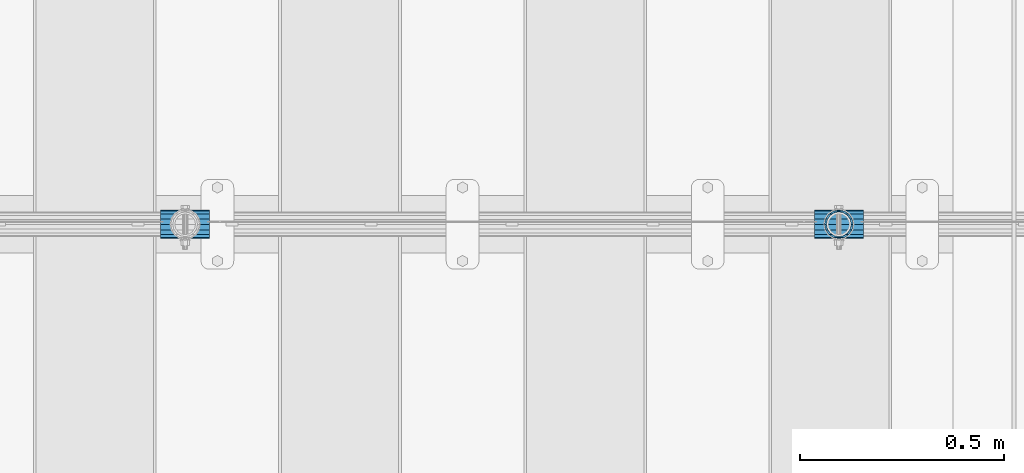
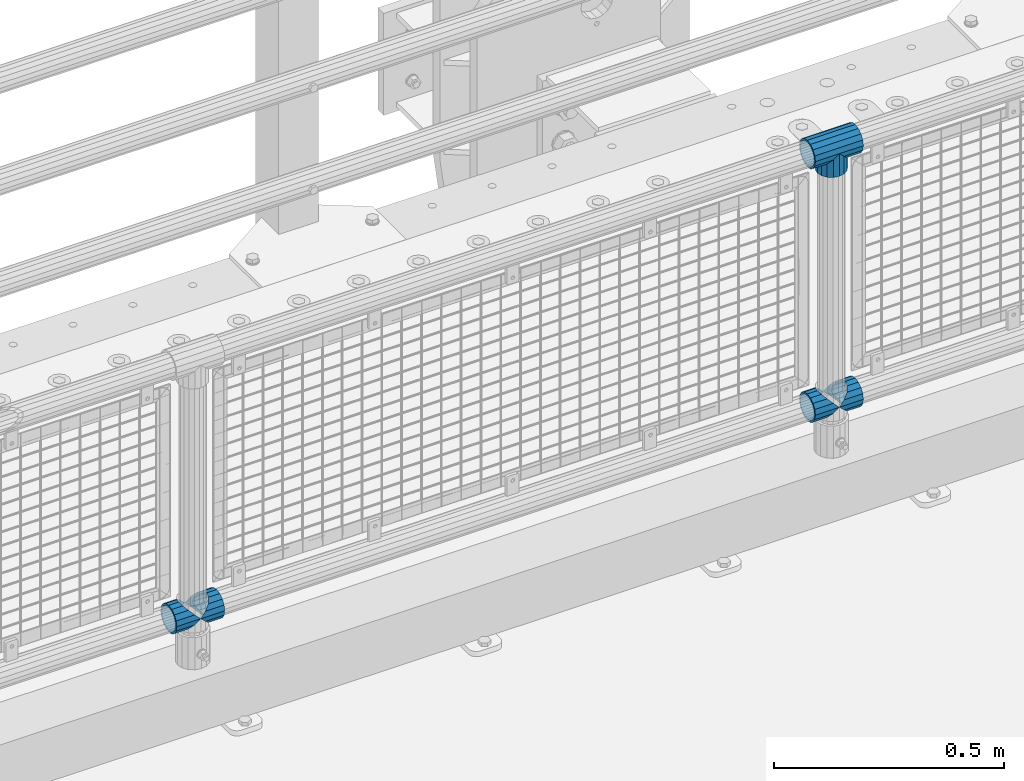
# One storey, part 156 of 257: 6 beams.
"""IFC2X3 building model written with IfcOpenShell, lengths in millimetres."""

from ifc_helpers import new_model, si_unit, frame, origin_with_axes, place, context, subcontext, project, spatial, faceted_brep, material, type_object, element, save


model = new_model("IFC2X3")

# Units and contexts
model_context = context("Model", 3, precision=1e-05, world=origin_with_axes())
body_context = subcontext(model_context, "Body", "Model", "MODEL_VIEW")
ifc_project = project(units=[si_unit("LENGTHUNIT", "METRE", prefix="MILLI"), si_unit("AREAUNIT", "SQUARE_METRE"), si_unit("VOLUMEUNIT", "CUBIC_METRE"), si_unit("MASSUNIT", "GRAM", prefix="KILO"), si_unit("TIMEUNIT", "SECOND"), si_unit("PLANEANGLEUNIT", "RADIAN"), si_unit("SOLIDANGLEUNIT", "STERADIAN"), si_unit("THERMODYNAMICTEMPERATUREUNIT", "DEGREE_CELSIUS"), si_unit("LUMINOUSINTENSITYUNIT", "LUMEN")], contexts=[model_context])

# Site, building, storey
site_placement = place(None, origin_with_axes())
site = spatial("IfcSite", under=ifc_project, at=site_placement, CompositionType="ELEMENT")
building_placement = place(site_placement, origin_with_axes())
building = spatial("IfcBuilding", under=site, at=building_placement, Name="Standard", CompositionType="ELEMENT")
storey_placement = place(building_placement, origin_with_axes())
storey = spatial("IfcBuildingStorey", under=building, at=storey_placement, Name="Undefined", CompositionType="ELEMENT", Elevation=0.0)

# Beams
ifc_material = material(Name="Misc_Undefined")
beam_type = type_object("IfcBeamType", PredefinedType="NOTDEFINED")
beam_1_placement = place(storey_placement, frame((54271.0, 10664.5, 969.849999999999), z_axis=(0.0, 1.0, 0.0), x_axis=(0.0, 0.0, -1.0)))
element("IfcBeam", 1, at=beam_1_placement, inside=storey, type_object=beam_type, material=ifc_material, context=body_context, shape_type="Brep", body=[
    faceted_brep([(0.0, 0.0, 35.1499999999996), (13.4513226476338, 13.4513226476329, 32.4743655677721), (13.4513226476338, -13.4513226476329, 32.4743655677721), (32.4743655677739, -32.4743655677717, -13.4513226476338), (32.4743655677739, -26.8123795176755, -13.4513226476338), (27.1226768591005, -21.4606908090117, -21.4606908090118), (24.8548033587067, -16.3810424080045, -24.8548033587067), (24.8548033587067, -24.8548033587072, -24.8548033587067), (13.4513226476338, -13.4513226476329, -32.4743655677721), (13.4513226476338, 13.4513226476329, -32.4743655677721), (0.0, 0.0, -35.1499999999996), (20.0882031229849, -11.6144421722805, -28.0397438117179), (16.6306603983685, 0.0, -30.3500000000004), (20.0882031229849, 11.6144421722805, -28.0397438117179), (24.8548033587067, 16.3810424080013, -24.8548033587067), (24.8548033587067, 24.8548033587072, -24.8548033587067), (32.4743655677739, 26.8123795176754, -13.4513226476338), (32.4743655677739, 32.4743655677717, -13.4513226476338), (27.1226768591005, 21.4606908090117, -21.4606908090118), (35.1500000000015, 30.35, 0.0), (35.1500000000015, 35.15, 0.0), (32.8397438117172, 28.0397438117175, -11.6144421722802), (32.8397438117172, 28.0397438117175, 11.6144421722802), (32.4743655677739, 26.8123795176755, 13.4513226476338), (32.4743655677739, 32.4743655677717, 13.4513226476338), (27.122676859115, 21.4606908090117, 21.4606908090118), (24.8548033587067, 16.3810424080013, 24.8548033587067), (24.8548033587067, 24.8548033587072, 24.8548033587067), (20.0882031229849, 11.6144421722805, 28.0397438117179), (16.6306603983758, 0.0, 30.3500000000004), (20.0882031229849, -11.6144421722805, 28.0397438117179), (24.8548033587067, -16.3810424080013, 24.8548033587067), (24.8548033587067, -24.8548033587072, 24.8548033587067), (27.122676859115, -21.4606908090117, 21.4606908090118), (32.4743655677739, -26.8123795176754, 13.4513226476338), (32.4743655677739, -32.4743655677717, 13.4513226476338), (32.8397438117172, -28.0397438117175, 11.6144421722802), (35.1500000000015, -30.35, 0.0), (35.1500000000015, -35.1499999999996, 0.0), (32.8397438117172, -28.0397438117175, -11.6144421722802), (60.1500000000015, -24.8548033587072, -24.8548033587067), (60.1500000000015, -32.4743655677717, -13.4513226476338), (60.1500000000015, -13.4513226476329, -32.4743655677721), (60.1500000000015, 0.0, -35.1499999999996), (60.1500000000015, 13.4513226476329, -32.4743655677721), (60.1500000000015, 24.8548033587072, -24.8548033587067), (60.1500000000015, 32.4743655677717, -13.4513226476338), (60.1500000000015, 35.15, 0.0), (60.1500000000015, 32.4743655677717, 13.4513226476338), (60.1500000000015, 24.8548033587072, 24.8548033587067), (60.1500000000015, 13.4513226476329, 32.4743655677721), (60.1500000000015, 0.0, 35.1499999999996), (60.1500000000015, -13.4513226476329, 32.4743655677721), (60.1500000000015, -24.8548033587072, 24.8548033587067), (60.1500000000015, -32.4743655677717, 13.4513226476338), (60.1500000000015, -35.15, 0.0), (60.1500000000015, -21.4606908090117, 21.4606908090118), (60.1500000000015, -11.6144421722805, 28.0397438117179), (60.1500000000015, 0.0, 30.3500000000004), (60.1500000000015, 11.6144421722805, 28.0397438117179), (60.1500000000015, 21.4606908090117, 21.4606908090118), (60.1500000000015, 28.0397438117175, 11.6144421722802), (60.1500000000015, 30.35, 0.0), (60.1500000000015, 28.0397438117175, -11.6144421722802), (60.1500000000015, 21.4606908090117, -21.4606908090118), (60.1500000000015, 11.6144421722805, -28.0397438117179), (60.1500000000015, 0.0, -30.3500000000004), (60.1500000000015, -11.6144421722805, -28.0397438117179), (60.1500000000015, -21.4606908090117, -21.4606908090118), (60.1500000000015, -28.0397438117175, -11.6144421722802), (60.1500000000015, -30.35, 0.0), (60.1500000000015, -28.0397438117175, 11.6144421722802)], [[[0, 1, 2]], [[3, 4, 5, 6, 7]], [[8, 9, 10]], [[7, 6, 11, 12, 13, 14, 15, 9, 8]], [[16, 17, 15, 14, 18]], [[19, 20, 17, 16, 21]], [[22, 23, 24, 20, 19]], [[25, 26, 27, 24, 23]], [[2, 1, 27, 26, 28, 29, 30, 31, 32]], [[32, 31, 33, 34, 35]], [[35, 34, 36, 37, 38]], [[38, 37, 39, 4, 3]], [[40, 41, 3, 7]], [[42, 40, 7, 8]], [[43, 42, 8, 10]], [[44, 43, 10, 9]], [[45, 44, 9, 15]], [[46, 45, 15, 17]], [[47, 46, 17, 20]], [[48, 47, 20, 24]], [[49, 48, 24, 27]], [[50, 49, 27, 1]], [[51, 50, 1, 0]], [[52, 51, 0, 2]], [[53, 52, 2, 32]], [[54, 53, 32, 35]], [[55, 54, 35, 38]], [[41, 55, 38, 3]], [[40, 42, 43, 44, 45, 46, 47, 48, 49, 50, 51, 52, 53, 54, 55, 41], [56, 57, 58, 59, 60, 61, 62, 63, 64, 65, 66, 67, 68, 69, 70, 71]], [[71, 70, 37, 36]], [[33, 56, 71, 36, 34]], [[30, 57, 56, 33, 31]], [[58, 57, 30, 29]], [[59, 58, 29, 28]], [[60, 59, 28, 26, 25]], [[61, 60, 25, 23, 22]], [[62, 61, 22, 19]], [[63, 62, 19, 21]], [[18, 64, 63, 21, 16]], [[13, 65, 64, 18, 14]], [[66, 65, 13, 12]], [[67, 66, 12, 11]], [[68, 67, 11, 6, 5]], [[69, 68, 5, 4, 39]], [[70, 69, 39, 37]]]),
])
beam_2_placement = place(storey_placement, frame((54210.85, 10664.5, 969.849999999999), z_axis=(0.0, 0.0, 1.0), x_axis=(1.0, 0.0, 0.0)))
element("IfcBeam", 2, at=beam_2_placement, inside=storey, type_object=beam_type, material=ifc_material, context=body_context, shape_type="Brep", body=[
    faceted_brep([(88.1897438117157, -11.6144421722802, -28.0397438117176), (88.1897438117157, -11.6144421722802, -32.8397438117175), (86.962379517674, -13.4513226476338, -32.4743655677718), (81.6106908090151, -21.4606908090118, -27.122676859108), (81.6106908090151, -21.4606908090118, -21.4606908090117), (76.5310424080017, -24.8548033587067, -24.8548033587072), (71.7644421722798, -28.0397438117179, -20.0882031229829), (71.7644421722798, -28.0397438117179, -11.6144421722805), (60.1500000000015, -30.3500000000004, -16.6306603983671), (60.1500000000015, -30.35, 0.0), (48.5355578277231, -28.0397438117179, -20.0882031229829), (48.5355578277231, -28.0397438117179, -11.6144421722805), (43.7689575920012, -24.8548033587067, -24.8548033587072), (38.6893091909878, -21.4606908090118, -27.122676859108), (38.6893091909878, -21.4606908090118, -21.4606908090117), (33.3376204823144, -13.4513226476338, -32.4743655677718), (32.1102561882872, -11.6144421722802, -32.8397438117175), (32.1102561882872, -11.6144421722802, -28.0397438117176), (29.8000000000029, 0.0, -35.15), (29.8000000000029, 0.0, -30.35), (32.1102561882872, 11.6144421722802, -32.8397438117178), (32.1102561882872, 11.6144421722802, -28.0397438117176), (33.3376204823289, 13.4513226476338, -32.4743655677718), (38.6893091909878, 21.4606908090118, -27.1226768591091), (38.6893091909878, 21.4606908090118, -21.4606908090117), (43.7689575920012, 24.8548033587067, -24.8548033587072), (48.5355578277231, 28.0397438117179, -20.0882031229829), (48.5355578277231, 28.0397438117179, -11.6144421722805), (60.1500000000015, 30.3500000000004, -16.6306603983671), (60.1500000000015, 30.35, 0.0), (71.7644421722798, 28.0397438117179, -20.0882031229829), (71.7644421722798, 28.0397438117179, -11.6144421722805), (76.5310424080017, 24.8548033587067, -24.8548033587072), (81.6106908090151, 21.4606908090118, -27.1226768591091), (81.6106908090151, 21.4606908090118, -21.4606908090117), (86.9623795176813, 13.4513226476338, -32.4743655677718), (88.1897438117157, 11.6144421722802, -32.8397438117178), (88.1897438117157, 11.6144421722802, -28.0397438117176), (90.5, 0.0, -35.15), (90.5, 0.0, -30.35), (0.0, -21.4606908090118, -21.4606908090136), (0.0, -28.0397438117179, -11.6144421722784), (0.0, -11.6144421722802, -28.0397438117143), (0.0, 0.0, -30.3499999999985), (0.0, 11.6144421722802, -28.0397438117143), (0.0, 21.4606908090118, -21.4606908090136), (0.0, 28.0397438117179, -11.6144421722784), (0.0, 30.3500000000004, 0.0), (0.0, 32.4743655677721, -13.4513226476338), (0.0, 35.1499999999996, 0.0), (120.300000000003, 35.1499999999996, 0.0), (120.300000000003, 32.4743655677721, -13.4513226476329), (0.0, 32.4743655677721, 13.4513226476338), (120.300000000003, 32.4743655677721, 13.4513226476329), (0.0, 24.8548033587067, 24.8548033587067), (120.300000000003, 24.8548033587067, 24.8548033587072), (0.0, 13.4513226476338, 32.4743655677739), (120.300000000003, 13.4513226476338, 32.4743655677718), (0.0, 0.0, 35.1499999999996), (120.300000000003, 0.0, 35.15), (0.0, -13.4513226476338, 32.4743655677739), (120.300000000003, -13.4513226476338, 32.4743655677718), (0.0, -24.8548033587067, 24.8548033587067), (120.300000000003, -24.8548033587067, 24.8548033587072), (0.0, -32.4743655677721, 13.4513226476338), (120.300000000003, -32.4743655677721, 13.4513226476329), (0.0, -35.1499999999996, 0.0), (120.300000000003, -35.1499999999996, 0.0), (0.0, -32.4743655677721, -13.4513226476338), (120.300000000003, -32.4743655677721, -13.4513226476329), (0.0, 24.8548033587067, -24.8548033587067), (0.0, 13.4513226476338, -32.4743655677739), (0.0, 0.0, -35.1499999999996), (0.0, -13.4513226476338, -32.4743655677739), (0.0, -24.8548033587067, -24.8548033587067), (0.0, 28.0397438117179, 11.6144421722784), (0.0, 21.4606908090118, 21.4606908090136), (0.0, 11.6144421722802, 28.0397438117143), (0.0, 0.0, 30.3499999999985), (0.0, -11.6144421722802, 28.0397438117143), (0.0, -21.4606908090118, 21.4606908090136), (0.0, -28.0397438117179, 11.6144421722784), (0.0, -30.3500000000004, 0.0), (120.300000000003, -30.3500000000004, 0.0), (120.300000000003, -28.0397438117179, -11.6144421722805), (120.300000000003, -21.4606908090118, -21.4606908090117), (120.300000000003, -11.6144421722802, -28.0397438117176), (120.300000000003, 0.0, -30.35), (120.300000000003, 21.4606908090118, -21.4606908090117), (120.300000000003, 28.0397438117179, -11.6144421722805), (120.300000000003, 11.6144421722802, -28.0397438117176), (120.300000000003, 30.3500000000004, 0.0), (120.300000000003, 28.0397438117179, 11.6144421722805), (120.300000000003, 21.4606908090118, 21.4606908090117), (120.300000000003, 11.6144421722802, 28.0397438117176), (120.300000000003, 0.0, 30.35), (120.300000000003, -11.6144421722802, 28.0397438117176), (120.300000000003, -21.4606908090118, 21.4606908090117), (120.300000000003, -28.0397438117179, 11.6144421722805), (120.300000000003, -24.8548033587067, -24.8548033587072), (120.300000000003, -13.4513226476338, -32.4743655677718), (120.300000000003, 0.0, -35.15), (120.300000000003, 13.4513226476338, -32.4743655677718), (120.300000000003, 24.8548033587067, -24.8548033587072)], [[[0, 1, 2, 3, 4]], [[4, 3, 5, 6, 7]], [[7, 6, 8, 9]], [[9, 8, 10, 11]], [[11, 10, 12, 13, 14]], [[14, 13, 15, 16, 17]], [[17, 16, 18, 19]], [[19, 18, 20, 21]], [[21, 20, 22, 23, 24]], [[24, 23, 25, 26, 27]], [[27, 26, 28, 29]], [[29, 28, 30, 31]], [[31, 30, 32, 33, 34]], [[34, 33, 35, 36, 37]], [[37, 36, 38, 39]], [[39, 38, 1, 0]], [[40, 41, 11, 14]], [[42, 40, 14, 17]], [[43, 42, 17, 19]], [[44, 43, 19, 21]], [[45, 44, 21, 24]], [[46, 45, 24, 27]], [[47, 46, 27, 29]], [[48, 49, 50, 51]], [[49, 52, 53, 50]], [[52, 54, 55, 53]], [[54, 56, 57, 55]], [[56, 58, 59, 57]], [[58, 60, 61, 59]], [[60, 62, 63, 61]], [[62, 64, 65, 63]], [[64, 66, 67, 65]], [[66, 68, 69, 67]], [[64, 62, 60, 58, 56, 54, 52, 49, 48, 70, 71, 72, 73, 74, 68, 66], [41, 40, 42, 43, 44, 45, 46, 47, 75, 76, 77, 78, 79, 80, 81, 82]], [[41, 82, 9, 11]], [[83, 84, 7, 9]], [[84, 85, 4, 7]], [[85, 86, 0, 4]], [[86, 87, 39, 0]], [[88, 89, 31, 34]], [[90, 88, 34, 37]], [[87, 90, 37, 39]], [[89, 91, 29, 31]], [[75, 47, 29, 91, 92]], [[76, 75, 92, 93]], [[77, 76, 93, 94]], [[78, 77, 94, 95]], [[79, 78, 95, 96]], [[80, 79, 96, 97]], [[81, 80, 97, 98]], [[9, 82, 81, 98, 83]], [[99, 100, 101, 102, 103, 51, 50, 53, 55, 57, 59, 61, 63, 65, 67, 69], [97, 96, 95, 94, 93, 92, 91, 89, 88, 90, 87, 86, 85, 84, 83, 98]], [[35, 102, 101, 38, 36]], [[32, 103, 102, 35, 33]], [[28, 26, 25, 70, 48, 51, 103, 32, 30]], [[22, 71, 70, 25, 23]], [[18, 72, 71, 22, 20]], [[73, 72, 18, 16, 15]], [[74, 73, 15, 13, 12]], [[99, 69, 68, 74, 12, 10, 8, 6, 5]], [[100, 99, 5, 3, 2]], [[101, 100, 2, 1, 38]]]),
])
beam_3_placement = place(storey_placement, frame((52610.85, 10664.5, 298.17), z_axis=(0.0, 1.0, 0.0), x_axis=(1.0, 0.0, 0.0)))
element("IfcBeam", 3, at=beam_3_placement, inside=storey, type_object=beam_type, material=ifc_material, context=body_context, shape_type="Brep", body=[
    faceted_brep([(60.1500000000015, 0.0, -35.1499999999996), (46.6986773523677, 13.4513226476329, -32.4743655677721), (46.6986773523677, -13.4513226476329, -32.4743655677721), (33.0273231408937, 21.4606908090117, 21.4606908090118), (27.6756344322275, 26.8123795176764, 13.4513226476338), (27.6756344322275, 32.4743655677717, 13.4513226476338), (35.2951966412948, 24.8548033587072, 24.8548033587067), (35.2951966412948, 16.3810424080013, 24.8548033587067), (27.3102561882843, 28.0397438117175, 11.6144421722802), (25.0, 30.35, 0.0), (25.0, 35.15, 0.0), (27.6756344322275, 26.8123795176754, -13.4513226476338), (27.6756344322275, 32.4743655677717, -13.4513226476338), (27.3102561882843, 28.0397438117175, -11.6144421722802), (35.2951966412948, 16.3810424080013, -24.8548033587067), (35.2951966412948, 24.8548033587072, -24.8548033587067), (33.0273231408864, 21.4606908090117, -21.4606908090118), (40.0617968770239, 11.6144421722805, -28.0397438117179), (43.5193396016475, 0.0, -30.3500000000004), (40.0617968770239, -11.6144421722805, -28.0397438117179), (35.2951966412948, -16.3810424080078, -24.8548033587067), (35.2951966412948, -24.8548033587072, -24.8548033587067), (33.0273231408864, -21.4606908090117, -21.4606908090118), (27.6756344322275, -26.8123795176764, -13.4513226476338), (27.6756344322275, -32.4743655677717, -13.4513226476338), (27.3102561882843, -28.0397438117175, -11.6144421722802), (25.0, -30.35, 0.0), (25.0, -35.15, 0.0), (27.3102561882843, -28.0397438117175, 11.6144421722802), (27.6756344322275, -26.8123795176754, 13.4513226476338), (27.6756344322275, -32.4743655677717, 13.4513226476338), (33.0273231408937, -21.4606908090117, 21.4606908090118), (35.2951966412948, -16.3810424080045, 24.8548033587067), (35.2951966412948, -24.8548033587072, 24.8548033587067), (60.1500000000015, 0.0, 35.1499999999996), (46.6986773523677, -13.4513226476329, 32.4743655677721), (46.6986773523677, 13.4513226476329, 32.4743655677721), (40.0617968770166, -11.6144421722805, 28.0397438117179), (43.519339601633, 0.0, 30.3500000000004), (40.0617968770166, 11.6144421722805, 28.0397438117179), (0.0, -32.4743655677721, -13.4513226476338), (0.0, -24.8548033587067, -24.8548033587067), (0.0, -13.4513226476338, -32.4743655677739), (0.0, 0.0, -35.1499999999996), (0.0, 13.4513226476338, -32.4743655677739), (0.0, 24.8548033587067, -24.8548033587067), (0.0, 32.4743655677721, -13.4513226476338), (0.0, 35.1499999999996, 0.0), (0.0, 32.4743655677721, 13.4513226476338), (0.0, 24.8548033587067, 24.8548033587067), (0.0, 13.4513226476338, 32.4743655677739), (0.0, 0.0, 35.1499999999996), (0.0, -32.4743655677721, 13.4513226476338), (0.0, -35.1499999999996, 0.0), (0.0, -24.8548033587067, 24.8548033587067), (0.0, -13.4513226476338, 32.4743655677739), (0.0, -28.0397438117179, -11.6144421722784), (0.0, -21.4606908090118, -21.4606908090136), (0.0, -11.6144421722802, -28.0397438117143), (0.0, 0.0, -30.3499999999985), (0.0, 11.6144421722802, -28.0397438117143), (0.0, 21.4606908090118, -21.4606908090136), (0.0, 28.0397438117179, -11.6144421722784), (0.0, 30.3500000000004, 0.0), (0.0, 28.0397438117179, 11.6144421722784), (0.0, 21.4606908090118, 21.4606908090136), (0.0, 11.6144421722802, 28.0397438117143), (0.0, 0.0, 30.3499999999985), (0.0, -11.6144421722802, 28.0397438117143), (0.0, -21.4606908090118, 21.4606908090136), (0.0, -28.0397438117179, 11.6144421722784), (0.0, -30.3500000000004, 0.0)], [[[0, 1, 2]], [[3, 4, 5, 6, 7]], [[8, 9, 10, 5, 4]], [[11, 12, 10, 9, 13]], [[14, 15, 12, 11, 16]], [[2, 1, 15, 14, 17, 18, 19, 20, 21]], [[21, 20, 22, 23, 24]], [[24, 23, 25, 26, 27]], [[27, 26, 28, 29, 30]], [[30, 29, 31, 32, 33]], [[34, 35, 36]], [[33, 32, 37, 38, 39, 7, 6, 36, 35]], [[40, 41, 21, 24]], [[41, 42, 2, 21]], [[42, 43, 0, 2]], [[43, 44, 1, 0]], [[44, 45, 15, 1]], [[45, 46, 12, 15]], [[46, 47, 10, 12]], [[47, 48, 5, 10]], [[48, 49, 6, 5]], [[49, 50, 36, 6]], [[50, 51, 34, 36]], [[52, 53, 27, 30]], [[54, 52, 30, 33]], [[55, 54, 33, 35]], [[51, 55, 35, 34]], [[53, 40, 24, 27]], [[52, 54, 55, 51, 50, 49, 48, 47, 46, 45, 44, 43, 42, 41, 40, 53], [56, 57, 58, 59, 60, 61, 62, 63, 64, 65, 66, 67, 68, 69, 70, 71]], [[68, 67, 38, 37]], [[31, 69, 68, 37, 32]], [[28, 70, 69, 31, 29]], [[71, 70, 28, 26]], [[56, 71, 26, 25]], [[57, 56, 25, 23, 22]], [[58, 57, 22, 20, 19]], [[59, 58, 19, 18]], [[60, 59, 18, 17]], [[16, 61, 60, 17, 14]], [[13, 62, 61, 16, 11]], [[63, 62, 13, 9]], [[64, 63, 9, 8]], [[65, 64, 8, 4, 3]], [[66, 65, 3, 7, 39]], [[67, 66, 39, 38]]]),
])
beam_4_placement = place(storey_placement, frame((52671.0, 10664.5, 298.17), z_axis=(0.0, 1.0, 0.0), x_axis=(1.0, 0.0, 0.0)))
element("IfcBeam", 4, at=beam_4_placement, inside=storey, type_object=beam_type, material=ifc_material, context=body_context, shape_type="Brep", body=[
    faceted_brep([(0.0, 0.0, 35.1499999999996), (13.4513226476338, 13.4513226476329, 32.4743655677721), (13.4513226476338, -13.4513226476329, 32.4743655677721), (32.4743655677739, -32.4743655677717, -13.4513226476338), (32.4743655677739, -26.8123795176755, -13.4513226476338), (27.1226768591005, -21.4606908090117, -21.4606908090118), (24.8548033587067, -16.3810424080045, -24.8548033587067), (24.8548033587067, -24.8548033587072, -24.8548033587067), (13.4513226476338, -13.4513226476329, -32.4743655677721), (13.4513226476338, 13.4513226476329, -32.4743655677721), (0.0, 0.0, -35.1499999999996), (20.0882031229849, -11.6144421722805, -28.0397438117179), (16.6306603983685, 0.0, -30.3500000000004), (20.0882031229849, 11.6144421722805, -28.0397438117179), (24.8548033587067, 16.3810424080013, -24.8548033587067), (24.8548033587067, 24.8548033587072, -24.8548033587067), (32.4743655677739, 26.8123795176754, -13.4513226476338), (32.4743655677739, 32.4743655677717, -13.4513226476338), (27.1226768591005, 21.4606908090117, -21.4606908090118), (35.1500000000015, 30.35, 0.0), (35.1500000000015, 35.15, 0.0), (32.8397438117172, 28.0397438117175, -11.6144421722802), (32.8397438117172, 28.0397438117175, 11.6144421722802), (32.4743655677739, 26.8123795176755, 13.4513226476338), (32.4743655677739, 32.4743655677717, 13.4513226476338), (27.122676859115, 21.4606908090117, 21.4606908090118), (24.8548033587067, 16.3810424080013, 24.8548033587067), (24.8548033587067, 24.8548033587072, 24.8548033587067), (20.0882031229849, 11.6144421722805, 28.0397438117179), (16.6306603983758, 0.0, 30.3500000000004), (20.0882031229849, -11.6144421722805, 28.0397438117179), (24.8548033587067, -16.3810424080013, 24.8548033587067), (24.8548033587067, -24.8548033587072, 24.8548033587067), (27.122676859115, -21.4606908090117, 21.4606908090118), (32.4743655677739, -26.8123795176754, 13.4513226476338), (32.4743655677739, -32.4743655677717, 13.4513226476338), (32.8397438117172, -28.0397438117175, 11.6144421722802), (35.1500000000015, -30.35, 0.0), (35.1500000000015, -35.1499999999996, 0.0), (32.8397438117172, -28.0397438117175, -11.6144421722802), (60.1500000000015, -24.8548033587072, -24.8548033587067), (60.1500000000015, -32.4743655677717, -13.4513226476338), (60.1500000000015, -13.4513226476329, -32.4743655677721), (60.1500000000015, 0.0, -35.1499999999996), (60.1500000000015, 13.4513226476329, -32.4743655677721), (60.1500000000015, 24.8548033587072, -24.8548033587067), (60.1500000000015, 32.4743655677717, -13.4513226476338), (60.1500000000015, 35.15, 0.0), (60.1500000000015, 32.4743655677717, 13.4513226476338), (60.1500000000015, 24.8548033587072, 24.8548033587067), (60.1500000000015, 13.4513226476329, 32.4743655677721), (60.1500000000015, 0.0, 35.1499999999996), (60.1500000000015, -13.4513226476329, 32.4743655677721), (60.1500000000015, -24.8548033587072, 24.8548033587067), (60.1500000000015, -32.4743655677717, 13.4513226476338), (60.1500000000015, -35.15, 0.0), (60.1500000000015, -21.4606908090117, 21.4606908090118), (60.1500000000015, -11.6144421722805, 28.0397438117179), (60.1500000000015, 0.0, 30.3500000000004), (60.1500000000015, 11.6144421722805, 28.0397438117179), (60.1500000000015, 21.4606908090117, 21.4606908090118), (60.1500000000015, 28.0397438117175, 11.6144421722802), (60.1500000000015, 30.35, 0.0), (60.1500000000015, 28.0397438117175, -11.6144421722802), (60.1500000000015, 21.4606908090117, -21.4606908090118), (60.1500000000015, 11.6144421722805, -28.0397438117179), (60.1500000000015, 0.0, -30.3500000000004), (60.1500000000015, -11.6144421722805, -28.0397438117179), (60.1500000000015, -21.4606908090117, -21.4606908090118), (60.1500000000015, -28.0397438117175, -11.6144421722802), (60.1500000000015, -30.35, 0.0), (60.1500000000015, -28.0397438117175, 11.6144421722802)], [[[0, 1, 2]], [[3, 4, 5, 6, 7]], [[8, 9, 10]], [[7, 6, 11, 12, 13, 14, 15, 9, 8]], [[16, 17, 15, 14, 18]], [[19, 20, 17, 16, 21]], [[22, 23, 24, 20, 19]], [[25, 26, 27, 24, 23]], [[2, 1, 27, 26, 28, 29, 30, 31, 32]], [[32, 31, 33, 34, 35]], [[35, 34, 36, 37, 38]], [[38, 37, 39, 4, 3]], [[40, 41, 3, 7]], [[42, 40, 7, 8]], [[43, 42, 8, 10]], [[44, 43, 10, 9]], [[45, 44, 9, 15]], [[46, 45, 15, 17]], [[47, 46, 17, 20]], [[48, 47, 20, 24]], [[49, 48, 24, 27]], [[50, 49, 27, 1]], [[51, 50, 1, 0]], [[52, 51, 0, 2]], [[53, 52, 2, 32]], [[54, 53, 32, 35]], [[55, 54, 35, 38]], [[41, 55, 38, 3]], [[40, 42, 43, 44, 45, 46, 47, 48, 49, 50, 51, 52, 53, 54, 55, 41], [56, 57, 58, 59, 60, 61, 62, 63, 64, 65, 66, 67, 68, 69, 70, 71]], [[71, 70, 37, 36]], [[33, 56, 71, 36, 34]], [[30, 57, 56, 33, 31]], [[58, 57, 30, 29]], [[59, 58, 29, 28]], [[60, 59, 28, 26, 25]], [[61, 60, 25, 23, 22]], [[62, 61, 22, 19]], [[63, 62, 19, 21]], [[18, 64, 63, 21, 16]], [[13, 65, 64, 18, 14]], [[66, 65, 13, 12]], [[67, 66, 12, 11]], [[68, 67, 11, 6, 5]], [[69, 68, 5, 4, 39]], [[70, 69, 39, 37]]]),
])
beam_5_placement = place(storey_placement, frame((54210.85, 10664.5, 298.17), z_axis=(0.0, 1.0, 0.0), x_axis=(1.0, 0.0, 0.0)))
element("IfcBeam", 5, at=beam_5_placement, inside=storey, type_object=beam_type, material=ifc_material, context=body_context, shape_type="Brep", body=[
    faceted_brep([(60.1500000000015, 0.0, -35.1499999999996), (46.6986773523677, 13.4513226476329, -32.4743655677721), (46.6986773523677, -13.4513226476329, -32.4743655677721), (33.0273231408937, 21.4606908090117, 21.4606908090118), (27.6756344322275, 26.8123795176764, 13.4513226476338), (27.6756344322275, 32.4743655677717, 13.4513226476338), (35.2951966412948, 24.8548033587072, 24.8548033587067), (35.2951966412948, 16.3810424080013, 24.8548033587067), (27.3102561882843, 28.0397438117175, 11.6144421722802), (25.0, 30.35, 0.0), (25.0, 35.15, 0.0), (27.6756344322275, 26.8123795176754, -13.4513226476338), (27.6756344322275, 32.4743655677717, -13.4513226476338), (27.3102561882843, 28.0397438117175, -11.6144421722802), (35.2951966412948, 16.3810424080013, -24.8548033587067), (35.2951966412948, 24.8548033587072, -24.8548033587067), (33.0273231408864, 21.4606908090117, -21.4606908090118), (40.0617968770239, 11.6144421722805, -28.0397438117179), (43.5193396016475, 0.0, -30.3500000000004), (40.0617968770239, -11.6144421722805, -28.0397438117179), (35.2951966412948, -16.3810424080078, -24.8548033587067), (35.2951966412948, -24.8548033587072, -24.8548033587067), (33.0273231408864, -21.4606908090117, -21.4606908090118), (27.6756344322275, -26.8123795176764, -13.4513226476338), (27.6756344322275, -32.4743655677717, -13.4513226476338), (27.3102561882843, -28.0397438117175, -11.6144421722802), (25.0, -30.35, 0.0), (25.0, -35.15, 0.0), (27.3102561882843, -28.0397438117175, 11.6144421722802), (27.6756344322275, -26.8123795176754, 13.4513226476338), (27.6756344322275, -32.4743655677717, 13.4513226476338), (33.0273231408937, -21.4606908090117, 21.4606908090118), (35.2951966412948, -16.3810424080045, 24.8548033587067), (35.2951966412948, -24.8548033587072, 24.8548033587067), (60.1500000000015, 0.0, 35.1499999999996), (46.6986773523677, -13.4513226476329, 32.4743655677721), (46.6986773523677, 13.4513226476329, 32.4743655677721), (40.0617968770166, -11.6144421722805, 28.0397438117179), (43.519339601633, 0.0, 30.3500000000004), (40.0617968770166, 11.6144421722805, 28.0397438117179), (0.0, -32.4743655677721, -13.4513226476338), (0.0, -24.8548033587067, -24.8548033587067), (0.0, -13.4513226476338, -32.4743655677739), (0.0, 0.0, -35.1499999999996), (0.0, 13.4513226476338, -32.4743655677739), (0.0, 24.8548033587067, -24.8548033587067), (0.0, 32.4743655677721, -13.4513226476338), (0.0, 35.1499999999996, 0.0), (0.0, 32.4743655677721, 13.4513226476338), (0.0, 24.8548033587067, 24.8548033587067), (0.0, 13.4513226476338, 32.4743655677739), (0.0, 0.0, 35.1499999999996), (0.0, -32.4743655677721, 13.4513226476338), (0.0, -35.1499999999996, 0.0), (0.0, -24.8548033587067, 24.8548033587067), (0.0, -13.4513226476338, 32.4743655677739), (0.0, -28.0397438117179, -11.6144421722784), (0.0, -21.4606908090118, -21.4606908090136), (0.0, -11.6144421722802, -28.0397438117143), (0.0, 0.0, -30.3499999999985), (0.0, 11.6144421722802, -28.0397438117143), (0.0, 21.4606908090118, -21.4606908090136), (0.0, 28.0397438117179, -11.6144421722784), (0.0, 30.3500000000004, 0.0), (0.0, 28.0397438117179, 11.6144421722784), (0.0, 21.4606908090118, 21.4606908090136), (0.0, 11.6144421722802, 28.0397438117143), (0.0, 0.0, 30.3499999999985), (0.0, -11.6144421722802, 28.0397438117143), (0.0, -21.4606908090118, 21.4606908090136), (0.0, -28.0397438117179, 11.6144421722784), (0.0, -30.3500000000004, 0.0)], [[[0, 1, 2]], [[3, 4, 5, 6, 7]], [[8, 9, 10, 5, 4]], [[11, 12, 10, 9, 13]], [[14, 15, 12, 11, 16]], [[2, 1, 15, 14, 17, 18, 19, 20, 21]], [[21, 20, 22, 23, 24]], [[24, 23, 25, 26, 27]], [[27, 26, 28, 29, 30]], [[30, 29, 31, 32, 33]], [[34, 35, 36]], [[33, 32, 37, 38, 39, 7, 6, 36, 35]], [[40, 41, 21, 24]], [[41, 42, 2, 21]], [[42, 43, 0, 2]], [[43, 44, 1, 0]], [[44, 45, 15, 1]], [[45, 46, 12, 15]], [[46, 47, 10, 12]], [[47, 48, 5, 10]], [[48, 49, 6, 5]], [[49, 50, 36, 6]], [[50, 51, 34, 36]], [[52, 53, 27, 30]], [[54, 52, 30, 33]], [[55, 54, 33, 35]], [[51, 55, 35, 34]], [[53, 40, 24, 27]], [[52, 54, 55, 51, 50, 49, 48, 47, 46, 45, 44, 43, 42, 41, 40, 53], [56, 57, 58, 59, 60, 61, 62, 63, 64, 65, 66, 67, 68, 69, 70, 71]], [[68, 67, 38, 37]], [[31, 69, 68, 37, 32]], [[28, 70, 69, 31, 29]], [[71, 70, 28, 26]], [[56, 71, 26, 25]], [[57, 56, 25, 23, 22]], [[58, 57, 22, 20, 19]], [[59, 58, 19, 18]], [[60, 59, 18, 17]], [[16, 61, 60, 17, 14]], [[13, 62, 61, 16, 11]], [[63, 62, 13, 9]], [[64, 63, 9, 8]], [[65, 64, 8, 4, 3]], [[66, 65, 3, 7, 39]], [[67, 66, 39, 38]]]),
])
beam_6_placement = place(storey_placement, frame((54271.0, 10664.5, 298.17), z_axis=(0.0, 1.0, 0.0), x_axis=(1.0, 0.0, 0.0)))
element("IfcBeam", 6, at=beam_6_placement, inside=storey, type_object=beam_type, material=ifc_material, context=body_context, shape_type="Brep", body=[
    faceted_brep([(0.0, 0.0, 35.1499999999996), (13.4513226476338, 13.4513226476329, 32.4743655677721), (13.4513226476338, -13.4513226476329, 32.4743655677721), (32.4743655677739, -32.4743655677717, -13.4513226476338), (32.4743655677739, -26.8123795176755, -13.4513226476338), (27.1226768591005, -21.4606908090117, -21.4606908090118), (24.8548033587067, -16.3810424080045, -24.8548033587067), (24.8548033587067, -24.8548033587072, -24.8548033587067), (13.4513226476338, -13.4513226476329, -32.4743655677721), (13.4513226476338, 13.4513226476329, -32.4743655677721), (0.0, 0.0, -35.1499999999996), (20.0882031229849, -11.6144421722805, -28.0397438117179), (16.6306603983685, 0.0, -30.3500000000004), (20.0882031229849, 11.6144421722805, -28.0397438117179), (24.8548033587067, 16.3810424080013, -24.8548033587067), (24.8548033587067, 24.8548033587072, -24.8548033587067), (32.4743655677739, 26.8123795176754, -13.4513226476338), (32.4743655677739, 32.4743655677717, -13.4513226476338), (27.1226768591005, 21.4606908090117, -21.4606908090118), (35.1500000000015, 30.35, 0.0), (35.1500000000015, 35.15, 0.0), (32.8397438117172, 28.0397438117175, -11.6144421722802), (32.8397438117172, 28.0397438117175, 11.6144421722802), (32.4743655677739, 26.8123795176755, 13.4513226476338), (32.4743655677739, 32.4743655677717, 13.4513226476338), (27.122676859115, 21.4606908090117, 21.4606908090118), (24.8548033587067, 16.3810424080013, 24.8548033587067), (24.8548033587067, 24.8548033587072, 24.8548033587067), (20.0882031229849, 11.6144421722805, 28.0397438117179), (16.6306603983758, 0.0, 30.3500000000004), (20.0882031229849, -11.6144421722805, 28.0397438117179), (24.8548033587067, -16.3810424080013, 24.8548033587067), (24.8548033587067, -24.8548033587072, 24.8548033587067), (27.122676859115, -21.4606908090117, 21.4606908090118), (32.4743655677739, -26.8123795176754, 13.4513226476338), (32.4743655677739, -32.4743655677717, 13.4513226476338), (32.8397438117172, -28.0397438117175, 11.6144421722802), (35.1500000000015, -30.35, 0.0), (35.1500000000015, -35.1499999999996, 0.0), (32.8397438117172, -28.0397438117175, -11.6144421722802), (60.1500000000015, -24.8548033587072, -24.8548033587067), (60.1500000000015, -32.4743655677717, -13.4513226476338), (60.1500000000015, -13.4513226476329, -32.4743655677721), (60.1500000000015, 0.0, -35.1499999999996), (60.1500000000015, 13.4513226476329, -32.4743655677721), (60.1500000000015, 24.8548033587072, -24.8548033587067), (60.1500000000015, 32.4743655677717, -13.4513226476338), (60.1500000000015, 35.15, 0.0), (60.1500000000015, 32.4743655677717, 13.4513226476338), (60.1500000000015, 24.8548033587072, 24.8548033587067), (60.1500000000015, 13.4513226476329, 32.4743655677721), (60.1500000000015, 0.0, 35.1499999999996), (60.1500000000015, -13.4513226476329, 32.4743655677721), (60.1500000000015, -24.8548033587072, 24.8548033587067), (60.1500000000015, -32.4743655677717, 13.4513226476338), (60.1500000000015, -35.15, 0.0), (60.1500000000015, -21.4606908090117, 21.4606908090118), (60.1500000000015, -11.6144421722805, 28.0397438117179), (60.1500000000015, 0.0, 30.3500000000004), (60.1500000000015, 11.6144421722805, 28.0397438117179), (60.1500000000015, 21.4606908090117, 21.4606908090118), (60.1500000000015, 28.0397438117175, 11.6144421722802), (60.1500000000015, 30.35, 0.0), (60.1500000000015, 28.0397438117175, -11.6144421722802), (60.1500000000015, 21.4606908090117, -21.4606908090118), (60.1500000000015, 11.6144421722805, -28.0397438117179), (60.1500000000015, 0.0, -30.3500000000004), (60.1500000000015, -11.6144421722805, -28.0397438117179), (60.1500000000015, -21.4606908090117, -21.4606908090118), (60.1500000000015, -28.0397438117175, -11.6144421722802), (60.1500000000015, -30.35, 0.0), (60.1500000000015, -28.0397438117175, 11.6144421722802)], [[[0, 1, 2]], [[3, 4, 5, 6, 7]], [[8, 9, 10]], [[7, 6, 11, 12, 13, 14, 15, 9, 8]], [[16, 17, 15, 14, 18]], [[19, 20, 17, 16, 21]], [[22, 23, 24, 20, 19]], [[25, 26, 27, 24, 23]], [[2, 1, 27, 26, 28, 29, 30, 31, 32]], [[32, 31, 33, 34, 35]], [[35, 34, 36, 37, 38]], [[38, 37, 39, 4, 3]], [[40, 41, 3, 7]], [[42, 40, 7, 8]], [[43, 42, 8, 10]], [[44, 43, 10, 9]], [[45, 44, 9, 15]], [[46, 45, 15, 17]], [[47, 46, 17, 20]], [[48, 47, 20, 24]], [[49, 48, 24, 27]], [[50, 49, 27, 1]], [[51, 50, 1, 0]], [[52, 51, 0, 2]], [[53, 52, 2, 32]], [[54, 53, 32, 35]], [[55, 54, 35, 38]], [[41, 55, 38, 3]], [[40, 42, 43, 44, 45, 46, 47, 48, 49, 50, 51, 52, 53, 54, 55, 41], [56, 57, 58, 59, 60, 61, 62, 63, 64, 65, 66, 67, 68, 69, 70, 71]], [[71, 70, 37, 36]], [[33, 56, 71, 36, 34]], [[30, 57, 56, 33, 31]], [[58, 57, 30, 29]], [[59, 58, 29, 28]], [[60, 59, 28, 26, 25]], [[61, 60, 25, 23, 22]], [[62, 61, 22, 19]], [[63, 62, 19, 21]], [[18, 64, 63, 21, 16]], [[13, 65, 64, 18, 14]], [[66, 65, 13, 12]], [[67, 66, 12, 11]], [[68, 67, 11, 6, 5]], [[69, 68, 5, 4, 39]], [[70, 69, 39, 37]]]),
])

save(model, "model.ifc")
